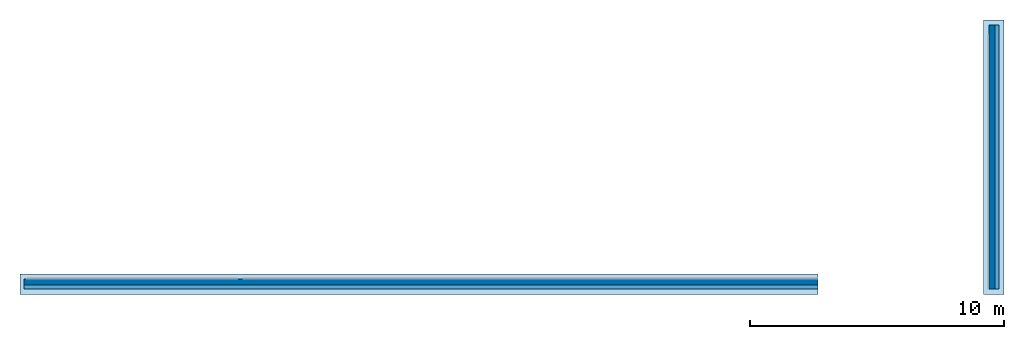
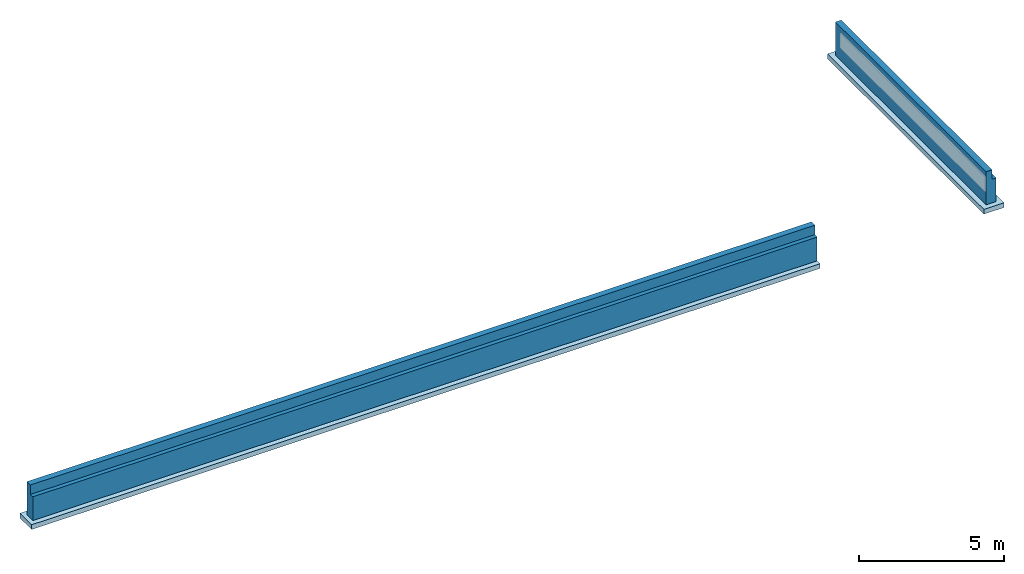
# One storey, part 1 of 2: 2 footings, 2 walls, 2 openings.
"""IFC4X3_ADD2 building model written with IfcOpenShell, lengths in millimetres."""

from ifc_helpers import new_model, entity, si_unit, converted_unit, frame, origin_with_axes, origin_2d_with_axis, place, context, subcontext, project, spatial, indexed_curve, outline, extrude, polygons, material, layer, layer_set, layer_usage, type_object, element, save


model = new_model("IFC4X3_ADD2")

# Units and contexts
model_context = context("Model", 3, precision=1e-05, world=origin_with_axes())
plan_context = context("Plan", 2, precision=1e-05, world=origin_2d_with_axis())
body_context = subcontext(model_context, "Body", "Model", "MODEL_VIEW")
ifc_project = project(units=[converted_unit("PLANEANGLEUNIT", "degree", entity("IfcReal", 0.0174532925199433), si_unit("PLANEANGLEUNIT", "RADIAN"), dimensions=[0, 0, 0, 0, 0, 0, 0]), si_unit("AREAUNIT", "SQUARE_METRE", prefix="MILLI"), si_unit("VOLUMEUNIT", "CUBIC_METRE", prefix="MILLI"), si_unit("LENGTHUNIT", "METRE", prefix="MILLI")], contexts=[model_context, plan_context])

# Site, building, storey
site_placement = place(None, frame((0.0, 0.0, -200.000002980232), z_axis=(0.0, 0.0, 1.0), x_axis=(1.0, 0.0, 0.0)))
site = spatial("IfcSite", under=ifc_project, at=site_placement)
building_placement = place(site_placement, frame((0.0, 0.0, 200.000002980232), z_axis=(0.0, 0.0, 1.0), x_axis=(1.0, 0.0, 0.0)))
building = spatial("IfcBuilding", under=site, at=building_placement, Name="001")
storey_placement = place(building_placement, frame((0.0, 0.0, -1400.00009536743), z_axis=(0.0, 0.0, 1.0), x_axis=(1.0, 0.0, 0.0)))
storey = spatial("IfcBuildingStorey", under=building, at=storey_placement, Name="-001 - TOP OF FOOTING")

# Footings
ifc_material = material(Name="Concrete", Category="03300 - Cast-in-place Concrete")
ifc_layer_1 = layer(ifc_material, 800.0, Name="Concrete", Category="Div03 - Conc")
ifc_layer_set_1 = layer_set([ifc_layer_1])
ifc_layer_usage_1 = layer_usage(ifc_layer_set_1, "AXIS2", "POSITIVE", 0.0)
footing_type = type_object("IfcFootingType", Name="WF8", PredefinedType="STRIP_FOOTING", material=ifc_layer_set_1)
footing_1_placement = place(storey_placement, frame((3033.81729125977, -3306.73789978027, -199.999928474428), z_axis=(0.0, 0.0, 1.0), x_axis=(1.0, 0.0, 0.0)))
element("IfcFooting", 1, at=footing_1_placement, inside=storey, type_object=footing_type, material=ifc_layer_usage_1, Name="Footing", context=body_context, shape_type="SweptSolid", body=[
    extrude(outline(indexed_curve([(0.0, 0.0), (0.0, 800.0), (31444.1032376178, 800.0), (31444.1032376178, 0.0), (0.0, 0.0)], self_intersect=False)), origin_with_axes(), (0.0, 0.0, 1.0), 200.000002980232),
])
ifc_layer_usage_2 = layer_usage(ifc_layer_set_1, "AXIS2", "POSITIVE", 0.0)
footing_2_placement = place(storey_placement, frame((41813.7474060059, -3306.73789978027, -199.999928474428), z_axis=(0.0, 0.0, 1.0), x_axis=(3.13916473260163e-07, 0.999999999999951, 0.0)))
element("IfcFooting", 2, at=footing_2_placement, inside=storey, type_object=footing_type, material=ifc_layer_usage_2, Name="Footing", context=body_context, shape_type="SweptSolid", body=[
    extrude(outline(indexed_curve([(0.0, 0.0), (0.0, 800.0), (10810.202646677, 800.0), (10810.202646677, 0.0), (0.0, 0.0)], self_intersect=False)), origin_with_axes(), (0.0, 0.0, 1.0), 200.000002980232),
])

# Wall, opening
ifc_layer_2 = layer(ifc_material, 400.0, Name="FDW", Category="Div 03")
ifc_layer_set_2 = layer_set([ifc_layer_2])
ifc_layer_usage_3 = layer_usage(ifc_layer_set_2, "AXIS2", "POSITIVE", 0.0)
wall_type = type_object("IfcWallType", Name="FDW- 400mm", PredefinedType="ELEMENTEDWALL", material=ifc_layer_set_2)
wall_1_placement = place(storey_placement, frame((41614.7804260254, -3107.69748687744, -1.55431223447522e-12), z_axis=(0.0, 0.0, 1.0), x_axis=(3.13916473260163e-07, 0.999999999999951, 0.0)))
wall_1 = element("IfcWall", 3, at=wall_1_placement, inside=storey, type_object=wall_type, material=ifc_layer_usage_3, Name="Wall.042", PredefinedType="ELEMENTEDWALL", context=body_context, shape_type="SweptSolid", body=[
    extrude(outline(indexed_curve([(0.0, 0.0), (0.0, 400.0), (10410.0063749772, 400.0), (10410.0063749772, 0.0), (0.0, 0.0)], self_intersect=False)), origin_with_axes(), (0.0, 0.0, 1.0), 1400.00009536743),
])
opening_1_placement = place(wall_1_placement, frame((186.152876591443, 186.153470301697, 1400.00009536743), z_axis=(0.0, 0.0, 1.0), x_axis=(1.0, -5.29395592033938e-23, 0.0)))
element("IfcOpeningElement", 4, at=opening_1_placement, inside=storey, cuts=wall_1, Name="Opening", context=body_context, shape_type="Tessellation", body=[
    polygons([(10223.8525390625, -21.5117607116699, -399.825653076172), (10223.8525390625, -186.150238037109, -399.825653076172), (-186.152465820312, -186.153350830078, -399.825653076172), (-186.152328491211, -21.5148620605469, -399.825653076172), (10223.8525390625, -21.5117607116699, 0.0), (10223.8525390625, -186.150238037109, 0.0), (-186.152465820312, -186.153350830078, 0.0), (-186.152328491211, -21.5148620605469, 0.0)], [[[1, 5, 6, 2]], [[4, 3, 7, 8]], [[5, 8, 7, 6]], [[8, 5, 1, 4]], [[6, 7, 3, 2]], [[2, 3, 4, 1]]], closed=True),
])

ifc_layer_usage_4 = layer_usage(ifc_layer_set_2, "AXIS2", "POSITIVE", 0.0)
wall_2_placement = place(storey_placement, frame((34477.9205322266, -2707.69619941711, -0.0182390213028238), z_axis=(0.0, 0.0, 1.0), x_axis=(-0.999999999999989, 1.50995802528085e-07, 0.0)))
wall_2 = element("IfcWall", 5, at=wall_2_placement, inside=storey, type_object=wall_type, material=ifc_layer_usage_4, Name="Wall.035", PredefinedType="ELEMENTEDWALL", context=body_context, shape_type="SweptSolid", body=[
    extrude(outline(indexed_curve([(0.0, 0.0), (0.0, 400.0), (31278.9250899896, 400.0), (31278.9250899896, 0.0), (0.0, 0.0)], self_intersect=False)), origin_with_axes(), (0.0, 0.0, 1.0), 1400.00009536743),
])
opening_2_placement = place(wall_2_placement, frame((31363.0065315391, 399.071422312594, 900.000035762787), z_axis=(0.0, 0.0, 1.0), x_axis=(1.0, 0.0, 0.0)))
element("IfcOpeningElement", 6, at=opening_2_placement, cuts=wall_2, Name="Opening", context=body_context, shape_type="Tessellation", body=[
    polygons([(2.98023187497165e-05, 0.92865514755249, 500.000030517578), (2.98023187497165e-05, 0.92865514755249, 100.018287658691), (-31363.0, 0.923991084098816, 100.036514282227), (-31363.0, 0.923991084098816, 500.018280029297), (-2.98023187497165e-05, -163.704376220703, 500.000030517578), (-2.98023187497165e-05, -163.704376220703, 100.018287658691), (-31363.0, -163.709014892578, 500.018280029297), (-31363.0, -163.709014892578, 100.036514282227)], [[[6, 2, 1, 5]], [[5, 7, 8, 6]], [[6, 8, 3, 2]], [[1, 4, 7, 5]], [[4, 3, 7]], [[3, 8, 7]], [[2, 3, 4, 1]]], closed=True),
])

save(model, "model.ifc")
